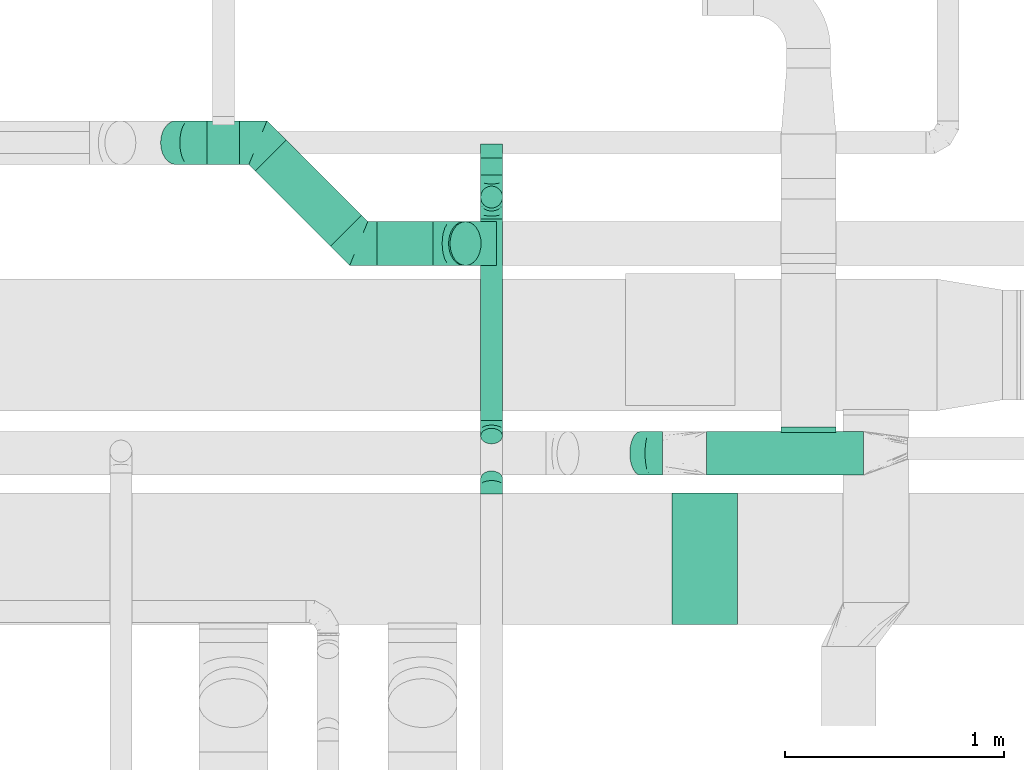
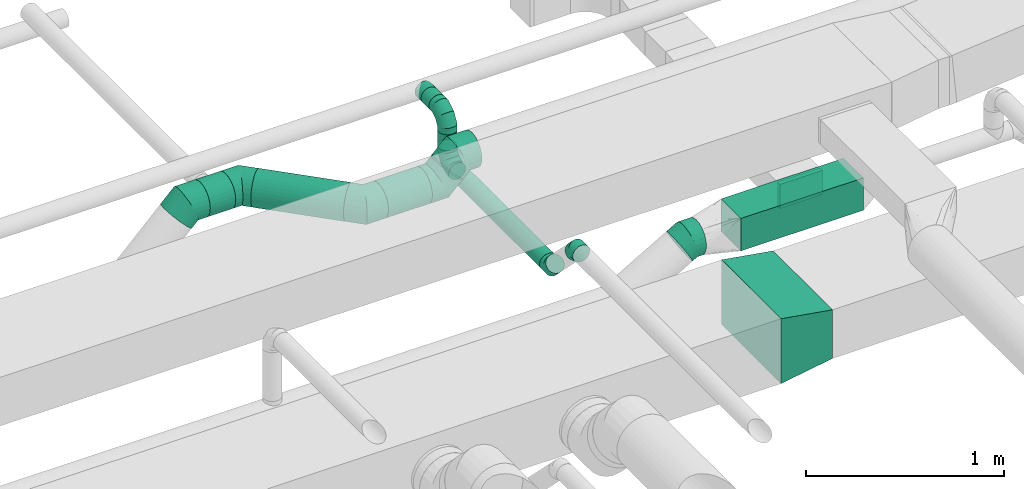
# One storey, part 42 of 60: 13 flow fittings, 8 flow segments.
"""IFC2X3 building model written with IfcOpenShell, lengths in millimetres."""

from ifc_helpers import new_model, entity, si_unit, converted_unit, derived_unit, direction, frame, origin, origin_2d_with_axis, place, context, subcontext, project, spatial, polyline, rectangle, circle, outline, extrude, faceted_brep, source, transform, mapped, material, type_object, type_shapes, element, save


model = new_model("IFC2X3")

# Units and contexts
model_context = context("Model", 3, precision=0.01, world=origin(), true_north=direction((6.12303176911189e-17, 1.0)))
body_context = subcontext(model_context, "Body", "Model", "MODEL_VIEW")
ifc_project = project(units=[si_unit("LENGTHUNIT", "METRE", prefix="MILLI"), si_unit("AREAUNIT", "SQUARE_METRE"), si_unit("VOLUMEUNIT", "CUBIC_METRE"), converted_unit("PLANEANGLEUNIT", "DEGREE", entity("IfcRatioMeasure", 0.0174532925199433), si_unit("PLANEANGLEUNIT", "RADIAN"), dimensions=[0, 0, 0, 0, 0, 0, 0]), si_unit("MASSUNIT", "GRAM", prefix="KILO"), derived_unit("MASSDENSITYUNIT", [(si_unit("MASSUNIT", "GRAM", prefix="KILO"), 1), (si_unit("LENGTHUNIT", "METRE"), -3)]), derived_unit("MOMENTOFINERTIAUNIT", [(si_unit("LENGTHUNIT", "METRE"), 4)]), si_unit("TIMEUNIT", "SECOND"), si_unit("FREQUENCYUNIT", "HERTZ"), si_unit("THERMODYNAMICTEMPERATUREUNIT", "DEGREE_CELSIUS"), derived_unit("THERMALTRANSMITTANCEUNIT", [(si_unit("MASSUNIT", "GRAM", prefix="KILO"), 1), (si_unit("THERMODYNAMICTEMPERATUREUNIT", "KELVIN"), -1), (si_unit("TIMEUNIT", "SECOND"), -3)]), derived_unit("VOLUMETRICFLOWRATEUNIT", [(si_unit("LENGTHUNIT", "METRE"), 3), (si_unit("TIMEUNIT", "SECOND"), -1)]), derived_unit("MASSFLOWRATEUNIT", [(si_unit("MASSUNIT", "GRAM", prefix="KILO"), 1), (si_unit("TIMEUNIT", "SECOND"), -1)]), derived_unit("ROTATIONALFREQUENCYUNIT", [(si_unit("TIMEUNIT", "SECOND"), -1)]), si_unit("ELECTRICCURRENTUNIT", "AMPERE"), si_unit("ELECTRICVOLTAGEUNIT", "VOLT"), si_unit("POWERUNIT", "WATT"), si_unit("FORCEUNIT", "NEWTON", prefix="KILO"), si_unit("ILLUMINANCEUNIT", "LUX"), si_unit("LUMINOUSFLUXUNIT", "LUMEN"), si_unit("LUMINOUSINTENSITYUNIT", "CANDELA"), derived_unit("USERDEFINED", [(si_unit("MASSUNIT", "GRAM", prefix="KILO"), -1), (si_unit("LENGTHUNIT", "METRE"), -2), (si_unit("TIMEUNIT", "SECOND"), 3), (si_unit("LUMINOUSFLUXUNIT", "LUMEN"), 1)]), derived_unit("LINEARVELOCITYUNIT", [(si_unit("LENGTHUNIT", "METRE"), 1), (si_unit("TIMEUNIT", "SECOND"), -1)]), si_unit("PRESSUREUNIT", "PASCAL"), derived_unit("USERDEFINED", [(si_unit("LENGTHUNIT", "METRE"), -2), (si_unit("MASSUNIT", "GRAM", prefix="KILO"), 1), (si_unit("TIMEUNIT", "SECOND"), -2)]), derived_unit("LINEARFORCEUNIT", [(si_unit("MASSUNIT", "GRAM", prefix="KILO"), 1), (si_unit("LENGTHUNIT", "METRE"), 1), (si_unit("TIMEUNIT", "SECOND"), -2), (si_unit("LENGTHUNIT", "METRE"), -1)]), derived_unit("PLANARFORCEUNIT", [(si_unit("MASSUNIT", "GRAM", prefix="KILO"), 1), (si_unit("LENGTHUNIT", "METRE"), 1), (si_unit("TIMEUNIT", "SECOND"), -2), (si_unit("LENGTHUNIT", "METRE"), -2)])], contexts=[model_context])

# Site, building, storey
site_placement = place(None, origin())
site = spatial("IfcSite", under=ifc_project, at=site_placement, CompositionType="ELEMENT")
building_placement = place(site_placement, origin())
building = spatial("IfcBuilding", under=site, at=building_placement, CompositionType="ELEMENT")
storey_placement = place(building_placement, frame((0.0, 0.0, 19800.0)))
storey = spatial("IfcBuildingStorey", under=building, at=storey_placement, CompositionType="ELEMENT", Elevation=19800.0)

# Flow segments
duct_segment_type_1 = type_object("IfcDuctSegmentType", PredefinedType="NOTDEFINED")
flow_segment_1_placement = place(storey_placement, frame((59695.58, 8770.01, 3225.0)))
element("IfcFlowSegment", 1, at=flow_segment_1_placement, inside=storey, type_object=duct_segment_type_1, context=body_context, shape_type="SweptSolid", body=[
    extrude(rectangle(XDim=714.972880388405, YDim=200.0, at=origin_2d_with_axis()), frame((357.49, 100.0, 0.0), z_axis=(0.0, 0.0, 1.0), x_axis=(-1.0, 0.0, 0.0)), (0.0, 0.0, 1.0), 199.999999999998),
])
duct_segment_type_2 = type_object("IfcDuctSegmentType", PredefinedType="NOTDEFINED")
flow_segment_2_placement = place(storey_placement, frame((58664.18, 9019.16, 3300.13)))
element("IfcFlowSegment", 2, at=flow_segment_2_placement, inside=storey, type_object=duct_segment_type_2, context=body_context, shape_type="SweptSolid", body=[
    extrude(circle(Radius=50.0, at=origin_2d_with_axis()), frame((51.6, 0.0, 51.6), z_axis=(0.0, 1.0, 0.0), x_axis=(1.0, 0.0, 0.0)), (0.0, 0.0, 1.0), 918.578643762716),
])
flow_segment_3_placement = place(storey_placement, frame((58664.18, 9986.14, 3451.72)))
element("IfcFlowSegment", 3, at=flow_segment_3_placement, inside=storey, type_object=duct_segment_type_2, context=body_context, shape_type="SweptSolid", body=[
    extrude(circle(Radius=50.0, at=origin_2d_with_axis()), frame((51.6, 51.6, 0.0), z_axis=(0.0, 0.0, 1.0), x_axis=(-1.0, 0.0, 0.0)), (0.0, 0.0, 1.0), 98.2773855639107),
])
flow_segment_4_placement = place(storey_placement, frame((58664.18, 10137.74, 3598.4)))
element("IfcFlowSegment", 4, at=flow_segment_4_placement, inside=storey, type_object=duct_segment_type_2, context=body_context, shape_type="SweptSolid", body=[
    extrude(circle(Radius=50.0, at=origin_2d_with_axis()), frame((51.6, 0.0, 51.6), z_axis=(0.0, 1.0, 0.0), x_axis=(-1.0, 0.0, 0.0)), (0.0, 0.0, 1.0), 77.8806642438999),
])
flow_segment_5_placement = place(storey_placement, frame((58518.17, 9724.4, 3412.43)))
element("IfcFlowSegment", 5, at=flow_segment_5_placement, inside=storey, type_object=duct_segment_type_2, context=body_context, shape_type="SweptSolid", body=[
    extrude(circle(Radius=100.0, at=origin_2d_with_axis()), frame((72.31, 101.6, 72.31), z_axis=(0.707106781186548, 0.0, 0.707106781186548), x_axis=(0.0, 1.0, 0.0)), (0.0, 0.0, 1.0), 9.46176130839337),
])
flow_segment_6_placement = place(storey_placement, frame((58193.08, 9724.4, 3324.56)))
element("IfcFlowSegment", 6, at=flow_segment_6_placement, inside=storey, type_object=duct_segment_type_2, context=body_context, shape_type="SweptSolid", body=[
    extrude(circle(Radius=100.0, at=origin_2d_with_axis()), frame((0.0, 101.6, 101.6), z_axis=(1.0, 0.0, 0.0), x_axis=(0.0, 1.0, 0.0)), (0.0, 0.0, 1.0), 255.972236219953),
])
flow_segment_7_placement = place(storey_placement, frame((57636.89, 9812.27, 3324.56)))
element("IfcFlowSegment", 7, at=flow_segment_7_placement, inside=storey, type_object=duct_segment_type_2, context=body_context, shape_type="SweptSolid", body=[
    extrude(circle(Radius=100.0, at=origin_2d_with_axis()), frame((72.31, 414.77, 101.6), z_axis=(0.707106781186523, -0.707106781186572, 0.0), x_axis=(0.707106781186572, 0.707106781186523, 0.0)), (0.0, 0.0, 1.0), 484.318928738875),
])
flow_segment_8_placement = place(storey_placement, frame((57419.32, 10184.02, 3324.56)))
element("IfcFlowSegment", 8, at=flow_segment_8_placement, inside=storey, type_object=duct_segment_type_2, context=body_context, shape_type="SweptSolid", body=[
    extrude(circle(Radius=100.0, at=origin_2d_with_axis()), frame((0.0, 101.6, 101.6), z_axis=(1.0, 0.0, 0.0), x_axis=(0.0, 1.0, 0.0)), (0.0, 0.0, 1.0), 148.455148137683),
])

# Flow fittings
ifc_material = material()
duct_fitting_type_1 = type_object("IfcDuctFittingType", PredefinedType="NOTDEFINED", material=ifc_material)
shared_shape_1 = source(origin(), body_context, "Body", "SweptSolid", [
    extrude(outline(polyline([(-123.27, -172.61), (180.87, -172.61), (115.05, 221.93), (-172.64, 123.3), (-123.27, -172.61)])), frame((150.0, -300.0, 0.03), z_axis=(0.0, 1.0, 0.0), x_axis=(0.986366827682647, 0.0, 0.164561481663454)), (0.0, 0.0, 1.0), 600.0),
])
type_shapes(duct_fitting_type_1, [shared_shape_1])
flow_fitting_1_placement = place(storey_placement, frame((59837.69, 8389.45, 3074.95), z_axis=(-8.63213559554975e-06, 0.0, 1.0), x_axis=(-1.0, 0.0, -8.63213559554975e-06)))
element("IfcFlowFitting", 9, at=flow_fitting_1_placement, inside=storey, type_object=duct_fitting_type_1, material=ifc_material, context=body_context, shape_type="MappedRepresentation", body=[
    mapped(shared_shape_1, transform((0.0, 0.0, 0.0), scale=1.0)),
])
duct_fitting_type_2 = type_object("IfcDuctFittingType", PredefinedType="NOTDEFINED", material=ifc_material)
shared_shape_2 = source(origin(), body_context, "Body", "SweptSolid", [
    extrude(rectangle(XDim=250.0, YDim=26.096, at=origin_2d_with_axis()), frame((6.95, 0.0, -75.0), z_axis=(0.0, 0.0, 1.0), x_axis=(0.0, -1.0, 0.0)), (0.0, 0.0, 1.0), 150.0),
])
type_shapes(duct_fitting_type_2, [shared_shape_2])
flow_fitting_2_placement = place(storey_placement, frame((60160.56, 8970.01, 3322.6), z_axis=(0.0, 0.0, -1.0), x_axis=(0.0, 1.0, 0.0)))
element("IfcFlowFitting", 10, at=flow_fitting_2_placement, inside=storey, type_object=duct_fitting_type_2, material=ifc_material, context=body_context, shape_type="MappedRepresentation", body=[
    mapped(shared_shape_2, transform((0.0, 0.0, 0.0), scale=1.0)),
])
duct_fitting_type_3 = type_object("IfcDuctFittingType", PredefinedType="NOTDEFINED", material=ifc_material)
shared_shape_3 = source(origin(), body_context, "Body", "Brep", [
    faceted_brep([(-100.0, 0.0, -50.0), (-100.0, -12.94, -48.3), (-100.0, -25.0, -43.3), (-100.0, -35.36, -35.36), (-100.0, -43.3, -25.0), (-100.0, -48.3, -12.94), (-100.0, -50.0, 0.0), (-100.0, -48.3, 12.94), (-100.0, -43.3, 25.0), (-100.0, -35.36, 35.36), (-100.0, -25.0, 43.3), (-100.0, -12.94, 48.3), (-100.0, 0.0, 50.0), (-100.0, 12.94, 48.3), (-100.0, 25.0, 43.3), (-100.0, 35.36, 35.36), (-100.0, 43.3, 25.0), (-100.0, 48.3, 12.94), (-100.0, 50.0, 0.0), (-100.0, 48.3, -12.94), (-100.0, 43.3, -25.0), (-100.0, 35.36, -35.36), (-100.0, 25.0, -43.3), (-100.0, 12.94, -48.3), (-76.67, 12.94, 48.3), (-79.9, 25.0, 43.3), (-73.21, 0.0, 50.0), (-82.68, 35.36, 35.36), (-86.15, 48.3, 12.94), (-86.6, 50.0, 0.0), (-84.81, 43.3, 25.0), (-84.81, 43.3, -25.0), (-82.68, 35.36, -35.36), (-86.15, 48.3, -12.94), (-76.67, 12.94, -48.3), (-73.21, 0.0, -50.0), (-79.9, 25.0, -43.3), (-69.74, -12.94, -48.3), (-66.51, -25.0, -43.3), (-63.73, -35.36, -35.36), (-61.6, -43.3, -25.0), (-60.26, -48.3, -12.94), (-59.81, -50.0, 0.0), (-60.26, -48.3, 12.94), (-61.6, -43.3, 25.0), (-63.73, -35.36, 35.36), (-66.51, -25.0, 43.3), (-69.74, -12.94, 48.3), (-36.27, 36.27, 48.3), (-45.1, 45.1, 43.3), (-26.79, 26.79, 50.0), (-52.68, 52.68, 35.36), (-58.49, 58.49, 25.0), (-62.15, 62.15, 12.94), (-63.4, 63.4, 0.0), (-62.15, 62.15, -12.94), (-58.49, 58.49, -25.0), (-52.68, 52.68, -35.36), (-36.27, 36.27, -48.3), (-26.79, 26.79, -50.0), (-45.1, 45.1, -43.3), (-17.32, 17.32, -48.3), (-8.49, 8.49, -43.3), (-0.91, 0.91, -35.36), (4.9, -4.9, -25.0), (8.56, -8.56, -12.94), (9.81, -9.81, 0.0), (8.56, -8.56, 12.94), (4.9, -4.9, 25.0), (-0.91, 0.91, 35.36), (-8.49, 8.49, 43.3), (-17.32, 17.32, 48.3), (-12.94, 76.67, 48.3), (-25.0, 79.9, 43.3), (0.0, 73.21, 50.0), (-35.36, 82.68, 35.36), (-43.3, 84.81, 25.0), (-48.3, 86.15, 12.94), (-50.0, 86.6, 0.0), (-48.3, 86.15, -12.94), (-43.3, 84.81, -25.0), (-35.36, 82.68, -35.36), (-12.94, 76.67, -48.3), (0.0, 73.21, -50.0), (-25.0, 79.9, -43.3), (12.94, 69.74, -48.3), (25.0, 66.51, -43.3), (35.36, 63.73, -35.36), (43.3, 61.6, -25.0), (48.3, 60.26, -12.94), (50.0, 59.81, 0.0), (48.3, 60.26, 12.94), (43.3, 61.6, 25.0), (35.36, 63.73, 35.36), (25.0, 66.51, 43.3), (12.94, 69.74, 48.3), (-12.94, 100.0, -48.3), (-25.0, 100.0, -43.3), (-35.36, 100.0, -35.36), (-43.3, 100.0, -25.0), (-48.3, 100.0, -12.94), (-50.0, 100.0, 0.0), (-48.3, 100.0, 12.94), (-43.3, 100.0, 25.0), (-35.36, 100.0, 35.36), (-25.0, 100.0, 43.3), (-12.94, 100.0, 48.3), (0.0, 100.0, 50.0), (12.94, 100.0, 48.3), (25.0, 100.0, 43.3), (35.36, 100.0, 35.36), (43.3, 100.0, 25.0), (48.3, 100.0, 12.94), (50.0, 100.0, 0.0), (48.3, 100.0, -12.94), (43.3, 100.0, -25.0), (35.36, 100.0, -35.36), (25.0, 100.0, -43.3), (12.94, 100.0, -48.3), (0.0, 100.0, -50.0)], [[[0, 1, 2, 3, 4, 5, 6, 7, 8, 9, 10, 11, 12, 13, 14, 15, 16, 17, 18, 19, 20, 21, 22, 23]], [[24, 25, 14, 13]], [[26, 24, 13, 12]], [[14, 25, 27, 15]], [[28, 29, 18, 17]], [[30, 28, 17, 16]], [[15, 27, 30, 16]], [[20, 31, 32, 21]], [[33, 31, 20, 19]], [[18, 29, 33, 19]], [[34, 35, 0, 23]], [[36, 34, 23, 22]], [[32, 36, 22, 21]], [[2, 1, 37, 38]], [[3, 2, 38, 39]], [[0, 35, 37, 1]], [[5, 4, 40, 41]], [[6, 5, 41, 42]], [[3, 39, 40, 4]], [[6, 42, 43, 7]], [[7, 43, 44, 8]], [[8, 44, 45, 9]], [[10, 46, 47, 11]], [[11, 47, 26, 12]], [[10, 9, 45, 46]], [[48, 49, 25, 24]], [[50, 48, 24, 26]], [[27, 25, 49, 51]], [[52, 53, 28, 30]], [[51, 52, 30, 27]], [[29, 28, 53, 54]], [[55, 56, 31, 33]], [[54, 55, 33, 29]], [[57, 32, 31, 56]], [[58, 59, 35, 34]], [[60, 58, 34, 36]], [[57, 60, 36, 32]], [[37, 35, 59, 61]], [[38, 37, 61, 62]], [[39, 38, 62, 63]], [[41, 40, 64, 65]], [[42, 41, 65, 66]], [[63, 64, 40, 39]], [[43, 42, 66, 67]], [[44, 43, 67, 68]], [[68, 69, 45, 44]], [[46, 45, 69, 70]], [[47, 46, 70, 71]], [[26, 47, 71, 50]], [[72, 73, 49, 48]], [[74, 72, 48, 50]], [[51, 49, 73, 75]], [[76, 77, 53, 52]], [[75, 76, 52, 51]], [[54, 53, 77, 78]], [[79, 80, 56, 55]], [[78, 79, 55, 54]], [[81, 57, 56, 80]], [[82, 83, 59, 58]], [[84, 82, 58, 60]], [[81, 84, 60, 57]], [[61, 59, 83, 85]], [[62, 61, 85, 86]], [[63, 62, 86, 87]], [[65, 64, 88, 89]], [[66, 65, 89, 90]], [[87, 88, 64, 63]], [[67, 66, 90, 91]], [[68, 67, 91, 92]], [[92, 93, 69, 68]], [[70, 69, 93, 94]], [[71, 70, 94, 95]], [[50, 71, 95, 74]], [[96, 97, 98, 99, 100, 101, 102, 103, 104, 105, 106, 107, 108, 109, 110, 111, 112, 113, 114, 115, 116, 117, 118, 119]], [[72, 74, 107, 106]], [[73, 72, 106, 105]], [[75, 73, 105, 104]], [[77, 76, 103, 102]], [[78, 77, 102, 101]], [[75, 104, 103, 76]], [[78, 101, 100, 79]], [[79, 100, 99, 80]], [[80, 99, 98, 81]], [[96, 119, 83, 82]], [[97, 96, 82, 84]], [[84, 81, 98, 97]], [[83, 119, 118, 85]], [[85, 118, 117, 86]], [[86, 117, 116, 87]], [[88, 115, 114, 89]], [[89, 114, 113, 90]], [[87, 116, 115, 88]], [[91, 90, 113, 112]], [[92, 91, 112, 111]], [[93, 92, 111, 110]], [[95, 94, 109, 108]], [[74, 95, 108, 107]], [[110, 109, 94, 93]]]),
])
type_shapes(duct_fitting_type_3, [shared_shape_3])
for number, where, z_axis, x_axis in (
    (11, (58715.78, 10037.74, 3351.72), (1.0, 0.0, 0.0), (0.0, 1.0, 0.0)),
    (12, (58715.78, 10037.74, 3650.0), (-1.0, 0.0, 0.0), (0.0, 0.0, 1.0)),
):
    element("IfcFlowFitting", number, at=place(storey_placement, frame(where, z_axis=z_axis, x_axis=x_axis)), inside=storey, type_object=duct_fitting_type_3, material=ifc_material, context=body_context, shape_type="MappedRepresentation", body=[
        mapped(shared_shape_3, transform((0.0, 0.0, 0.0), scale=1.0)),
    ])
duct_fitting_type_4 = type_object("IfcDuctFittingType", PredefinedType="NOTDEFINED", material=ifc_material)
shared_shape_4 = source(origin(), body_context, "Body", "Brep", [
    faceted_brep([(-41.42, 0.0, -50.0), (-41.42, -12.94, -48.3), (-41.42, -25.0, -43.3), (-41.42, -35.36, -35.36), (-41.42, -43.3, -25.0), (-41.42, -48.3, -12.94), (-41.42, -50.0, 0.0), (-41.42, -48.3, 12.94), (-41.42, -43.3, 25.0), (-41.42, -35.36, 35.36), (-41.42, -25.0, 43.3), (-41.42, -12.94, 48.3), (-41.42, 0.0, 50.0), (-41.42, 12.94, 48.3), (-41.42, 25.0, 43.3), (-41.42, 35.36, 35.36), (-41.42, 43.3, 25.0), (-41.42, 48.3, 12.94), (-41.42, 50.0, 0.0), (-41.42, 48.3, -12.94), (-41.42, 43.3, -25.0), (-41.42, 35.36, -35.36), (-41.42, 25.0, -43.3), (-41.42, 12.94, -48.3), (-5.36, 12.94, 48.3), (-10.36, 25.0, 43.3), (0.0, 0.0, 50.0), (-14.64, 35.36, 35.36), (-20.0, 48.3, 12.94), (-20.71, 50.0, 0.0), (-17.94, 43.3, 25.0), (-17.94, 43.3, -25.0), (-14.64, 35.36, -35.36), (-20.0, 48.3, -12.94), (-5.36, 12.94, -48.3), (0.0, 0.0, -50.0), (-10.36, 25.0, -43.3), (5.36, -12.94, -48.3), (10.36, -25.0, -43.3), (14.64, -35.36, -35.36), (17.94, -43.3, -25.0), (20.0, -48.3, -12.94), (20.71, -50.0, 0.0), (20.0, -48.3, 12.94), (17.94, -43.3, 25.0), (14.64, -35.36, 35.36), (10.36, -25.0, 43.3), (5.36, -12.94, 48.3), (29.29, 29.29, 50.0), (20.14, 38.44, 48.3), (11.61, 46.97, 43.3), (4.29, 54.29, 35.36), (-1.33, 59.91, 25.0), (-4.86, 63.44, 12.94), (-6.07, 64.64, 0.0), (-4.86, 63.44, -12.94), (-1.33, 59.91, -25.0), (4.29, 54.29, -35.36), (11.61, 46.97, -43.3), (20.14, 38.44, -48.3), (29.29, 29.29, -50.0), (38.44, 20.14, -48.3), (46.97, 11.61, -43.3), (54.29, 4.29, -35.36), (59.91, -1.33, -25.0), (63.44, -4.86, -12.94), (64.64, -6.07, 0.0), (63.44, -4.86, 12.94), (59.91, -1.33, 25.0), (54.29, 4.29, 35.36), (46.97, 11.61, 43.3), (38.44, 20.14, 48.3)], [[[0, 1, 2, 3, 4, 5, 6, 7, 8, 9, 10, 11, 12, 13, 14, 15, 16, 17, 18, 19, 20, 21, 22, 23]], [[24, 25, 14, 13]], [[26, 24, 13, 12]], [[14, 25, 27, 15]], [[28, 29, 18, 17]], [[30, 28, 17, 16]], [[16, 15, 27, 30]], [[20, 31, 32, 21]], [[33, 31, 20, 19]], [[18, 29, 33, 19]], [[34, 35, 0, 23]], [[36, 34, 23, 22]], [[32, 36, 22, 21]], [[1, 0, 35, 37]], [[2, 1, 37, 38]], [[38, 39, 3, 2]], [[5, 4, 40, 41]], [[6, 5, 41, 42]], [[39, 40, 4, 3]], [[6, 42, 43, 7]], [[7, 43, 44, 8]], [[8, 44, 45, 9]], [[9, 45, 46, 10]], [[10, 46, 47, 11]], [[26, 12, 11, 47]], [[24, 26, 48, 49]], [[25, 24, 49, 50]], [[27, 25, 50, 51]], [[28, 30, 52, 53]], [[29, 28, 53, 54]], [[27, 51, 52, 30]], [[29, 54, 55, 33]], [[33, 55, 56, 31]], [[31, 56, 57, 32]], [[36, 58, 59, 34]], [[34, 59, 60, 35]], [[36, 32, 57, 58]], [[61, 62, 38, 37]], [[60, 61, 37, 35]], [[63, 39, 38, 62]], [[40, 64, 65, 41]], [[41, 65, 66, 42]], [[64, 40, 39, 63]], [[43, 42, 66, 67]], [[44, 43, 67, 68]], [[68, 69, 45, 44]], [[47, 46, 70, 71]], [[26, 47, 71, 48]], [[69, 70, 46, 45]], [[59, 58, 57, 56, 55, 54, 53, 52, 51, 50, 49, 48, 71, 70, 69, 68, 67, 66, 65, 64, 63, 62, 61, 60]]]),
])
type_shapes(duct_fitting_type_4, [shared_shape_4])
for number, where, z_axis, x_axis in (
    (13, (58715.78, 8724.9, 3604.57), (-1.0, 0.0, 0.0), (0.0, 1.0, 0.0)),
    (14, (58715.78, 8977.74, 3351.72), (1.0, 0.0, 0.0), (0.0, 0.707106781186525, -0.70710678118657)),
):
    element("IfcFlowFitting", number, at=place(storey_placement, frame(where, z_axis=z_axis, x_axis=x_axis)), inside=storey, type_object=duct_fitting_type_4, material=ifc_material, context=body_context, shape_type="MappedRepresentation", body=[
        mapped(shared_shape_4, transform((0.0, 0.0, 0.0), scale=1.0)),
    ])
duct_fitting_type_5 = type_object("IfcDuctFittingType", PredefinedType="NOTDEFINED", material=ifc_material)
shared_shape_5 = source(origin(), body_context, "Body", "Brep", [
    faceted_brep([(20.0, 12.94, -48.3), (20.0, 25.0, -43.3), (20.0, 35.36, -35.36), (20.0, 43.3, -25.0), (20.0, 48.3, -12.94), (20.0, 50.0, 0.0), (20.0, 48.3, 12.94), (20.0, 43.3, 25.0), (20.0, 35.36, 35.36), (20.0, 25.0, 43.3), (20.0, 12.94, 48.3), (20.0, 0.0, 50.0), (20.0, -12.94, 48.3), (20.0, -25.0, 43.3), (20.0, -35.36, 35.36), (20.0, -43.3, 25.0), (20.0, -48.3, 12.94), (20.0, -50.0, 0.0), (20.0, -48.3, -12.94), (20.0, -43.3, -25.0), (20.0, -35.36, -35.36), (20.0, -25.0, -43.3), (20.0, -12.94, -48.3), (20.0, 0.0, -50.0), (0.0, 0.0, 50.0), (0.0, 12.94, 48.3), (-43.9, 12.94, 48.3), (-43.9, 0.0, 50.0), (0.0, 25.0, 43.3), (-43.9, 25.0, 43.3), (0.0, 35.36, 35.36), (-43.9, 35.36, 35.36), (0.0, 43.3, 25.0), (0.0, 48.3, 12.94), (-43.9, 48.3, 12.94), (-43.9, 43.3, 25.0), (0.0, 50.0, 0.0), (-43.9, 50.0, 0.0), (0.0, 48.3, -12.94), (-43.9, 48.3, -12.94), (0.0, 43.3, -25.0), (-43.9, 43.3, -25.0), (0.0, 35.36, -35.36), (-43.9, 35.36, -35.36), (0.0, 25.0, -43.3), (0.0, 12.94, -48.3), (-43.9, 12.94, -48.3), (-43.9, 25.0, -43.3), (0.0, 0.0, -50.0), (-43.9, 0.0, -50.0), (0.0, -12.94, -48.3), (-43.9, -12.94, -48.3), (0.0, -25.0, -43.3), (-43.9, -25.0, -43.3), (0.0, -35.36, -35.36), (-43.9, -35.36, -35.36), (0.0, -43.3, -25.0), (0.0, -48.3, -12.94), (-43.9, -48.3, -12.94), (-43.9, -43.3, -25.0), (0.0, -50.0, 0.0), (-43.9, -50.0, 0.0), (0.0, -48.3, 12.94), (-43.9, -48.3, 12.94), (0.0, -43.3, 25.0), (-43.9, -43.3, 25.0), (0.0, -35.36, 35.36), (-43.9, -35.36, 35.36), (0.0, -25.0, 43.3), (0.0, -12.94, 48.3), (-43.9, -12.94, 48.3), (-43.9, -25.0, 43.3)], [[[0, 1, 2, 3, 4, 5, 6, 7, 8, 9, 10, 11, 12, 13, 14, 15, 16, 17, 18, 19, 20, 21, 22, 23]], [[24, 11, 10, 25, 26, 27]], [[25, 10, 9, 28, 29, 26]], [[28, 9, 8, 30, 31, 29]], [[32, 7, 6, 33, 34, 35]], [[33, 6, 5, 36, 37, 34]], [[30, 8, 7, 32, 35, 31]], [[36, 5, 4, 38, 39, 37]], [[38, 4, 3, 40, 41, 39]], [[40, 3, 2, 42, 43, 41]], [[44, 1, 0, 45, 46, 47]], [[45, 0, 23, 48, 49, 46]], [[42, 2, 1, 44, 47, 43]], [[48, 23, 22, 50, 51, 49]], [[50, 22, 21, 52, 53, 51]], [[52, 21, 20, 54, 55, 53]], [[56, 19, 18, 57, 58, 59]], [[57, 18, 17, 60, 61, 58]], [[54, 20, 19, 56, 59, 55]], [[60, 17, 16, 62, 63, 61]], [[62, 16, 15, 64, 65, 63]], [[64, 15, 14, 66, 67, 65]], [[68, 13, 12, 69, 70, 71]], [[69, 12, 11, 24, 27, 70]], [[66, 14, 13, 68, 71, 67]], [[49, 51, 53, 55, 59, 58, 61, 63, 65, 67, 71, 70, 27, 26, 29, 31, 35, 34, 37, 39, 41, 43, 47, 46]]]),
])
type_shapes(duct_fitting_type_5, [shared_shape_5])
flow_fitting_3_placement = place(storey_placement, frame((58715.78, 10235.62, 3650.0), z_axis=(0.0, 0.0, -1.0), x_axis=(0.0, -1.0, 0.0)))
element("IfcFlowFitting", 15, at=flow_fitting_3_placement, inside=storey, type_object=duct_fitting_type_5, material=ifc_material, context=body_context, shape_type="MappedRepresentation", body=[
    mapped(shared_shape_5, transform((0.0, 0.0, 0.0), scale=1.0)),
])
duct_fitting_type_6 = type_object("IfcDuctFittingType", PredefinedType="NOTDEFINED", material=ifc_material)
shared_shape_6 = source(origin(), body_context, "Body", "Brep", [
    faceted_brep([(-82.84, 0.0, -100.0), (-82.84, -25.88, -96.59), (-82.84, -50.0, -86.6), (-82.84, -70.71, -70.71), (-82.84, -86.6, -50.0), (-82.84, -96.59, -25.88), (-82.84, -100.0, 0.0), (-82.84, -96.59, 25.88), (-82.84, -86.6, 50.0), (-82.84, -70.71, 70.71), (-82.84, -50.0, 86.6), (-82.84, -25.88, 96.59), (-82.84, 0.0, 100.0), (-82.84, 25.88, 96.59), (-82.84, 50.0, 86.6), (-82.84, 70.71, 70.71), (-82.84, 86.6, 50.0), (-82.84, 96.59, 25.88), (-82.84, 100.0, 0.0), (-82.84, 96.59, -25.88), (-82.84, 86.6, -50.0), (-82.84, 70.71, -70.71), (-82.84, 50.0, -86.6), (-82.84, 25.88, -96.59), (-10.72, 25.88, 96.59), (-20.71, 50.0, 86.6), (0.0, 0.0, 100.0), (-29.29, 70.71, 70.71), (-35.87, 86.6, 50.0), (-40.01, 96.59, 25.88), (-41.42, 100.0, 0.0), (-40.01, 96.59, -25.88), (-35.87, 86.6, -50.0), (-29.29, 70.71, -70.71), (-10.72, 25.88, -96.59), (0.0, 0.0, -100.0), (-20.71, 50.0, -86.6), (10.72, -25.88, -96.59), (20.71, -50.0, -86.6), (29.29, -70.71, -70.71), (35.87, -86.6, -50.0), (40.01, -96.59, -25.88), (41.42, -100.0, 0.0), (40.01, -96.59, 25.88), (35.87, -86.6, 50.0), (29.29, -70.71, 70.71), (20.71, -50.0, 86.6), (10.72, -25.88, 96.59), (58.58, 58.58, 100.0), (40.28, 76.88, 96.59), (23.22, 93.93, 86.6), (8.58, 108.58, 70.71), (-2.66, 119.82, 50.0), (-9.72, 126.88, 25.88), (-12.13, 129.29, 0.0), (-9.72, 126.88, -25.88), (-2.66, 119.82, -50.0), (8.58, 108.58, -70.71), (23.22, 93.93, -86.6), (40.28, 76.88, -96.59), (58.58, 58.58, -100.0), (76.88, 40.28, -96.59), (93.93, 23.22, -86.6), (108.58, 8.58, -70.71), (119.82, -2.66, -50.0), (126.88, -9.72, -25.88), (129.29, -12.13, 0.0), (126.88, -9.72, 25.88), (119.82, -2.66, 50.0), (108.58, 8.58, 70.71), (93.93, 23.22, 86.6), (76.88, 40.28, 96.59)], [[[0, 1, 2, 3, 4, 5, 6, 7, 8, 9, 10, 11, 12, 13, 14, 15, 16, 17, 18, 19, 20, 21, 22, 23]], [[24, 25, 14, 13]], [[26, 24, 13, 12]], [[14, 25, 27, 15]], [[28, 29, 17, 16]], [[28, 16, 15, 27]], [[30, 18, 17, 29]], [[31, 32, 20, 19]], [[30, 31, 19, 18]], [[32, 33, 21, 20]], [[34, 35, 0, 23]], [[36, 34, 23, 22]], [[33, 36, 22, 21]], [[1, 0, 35, 37]], [[2, 1, 37, 38]], [[38, 39, 3, 2]], [[5, 4, 40, 41]], [[6, 5, 41, 42]], [[39, 40, 4, 3]], [[6, 42, 43, 7]], [[7, 43, 44, 8]], [[8, 44, 45, 9]], [[9, 45, 46, 10]], [[10, 46, 47, 11]], [[26, 12, 11, 47]], [[24, 26, 48, 49]], [[25, 24, 49, 50]], [[27, 25, 50, 51]], [[29, 28, 52, 53]], [[30, 29, 53, 54]], [[51, 52, 28, 27]], [[30, 54, 55, 31]], [[31, 55, 56, 32]], [[57, 33, 32, 56]], [[36, 58, 59, 34]], [[34, 59, 60, 35]], [[58, 36, 33, 57]], [[35, 60, 61, 37]], [[37, 61, 62, 38]], [[63, 39, 38, 62]], [[40, 64, 65, 41]], [[41, 65, 66, 42]], [[64, 40, 39, 63]], [[43, 42, 66, 67]], [[44, 43, 67, 68]], [[68, 69, 45, 44]], [[47, 46, 70, 71]], [[26, 47, 71, 48]], [[69, 70, 46, 45]], [[59, 58, 57, 56, 55, 54, 53, 52, 51, 50, 49, 48, 71, 70, 69, 68, 67, 66, 65, 64, 63, 62, 61, 60]]]),
])
type_shapes(duct_fitting_type_6, [shared_shape_6])
for number, where, z_axis, x_axis in (
    (16, (58655.74, 9826.0, 3550.0), (0.0, -1.0, 0.0), (-1.0, 0.0, 0.0)),
    (17, (58531.9, 9826.0, 3426.16), (0.0, 1.0, 0.0), (-0.707106781186523, 0.0, -0.707106781186572)),
    (18, (58110.24, 9826.0, 3426.16), (0.0, 0.0, 1.0), (0.707106781186546, -0.707106781186549, 0.0)),
    (19, (57650.62, 10285.62, 3426.16), (0.0, 0.0, 1.0), (-0.707106781186534, 0.707106781186561, 0.0)),
    (20, (57336.47, 10285.62, 3426.16), (0.0, -1.0, 0.0), (-1.0, 0.0, 0.0)),
):
    element("IfcFlowFitting", number, at=place(storey_placement, frame(where, z_axis=z_axis, x_axis=x_axis)), inside=storey, type_object=duct_fitting_type_6, material=ifc_material, context=body_context, shape_type="MappedRepresentation", body=[
        mapped(shared_shape_6, transform((0.0, 0.0, 0.0), scale=1.0)),
    ])
duct_fitting_type_7 = type_object("IfcDuctFittingType", PredefinedType="NOTDEFINED", material=ifc_material)
shared_shape_7 = source(origin(), body_context, "Body", "Brep", [
    faceted_brep([(-53.59, 0.0, -100.0), (-53.59, -25.88, -96.59), (-53.59, -50.0, -86.6), (-53.59, -70.71, -70.71), (-53.59, -86.6, -50.0), (-53.59, -96.59, -25.88), (-53.59, -100.0, 0.0), (-53.59, -96.59, 25.88), (-53.59, -86.6, 50.0), (-53.59, -70.71, 70.71), (-53.59, -50.0, 86.6), (-53.59, -25.88, 96.59), (-53.59, 0.0, 100.0), (-53.59, 25.88, 96.59), (-53.59, 50.0, 86.6), (-53.59, 70.71, 70.71), (-53.59, 86.6, 50.0), (-53.59, 96.59, 25.88), (-53.59, 100.0, 0.0), (-53.59, 96.59, -25.88), (-53.59, 86.6, -50.0), (-53.59, 70.71, -70.71), (-53.59, 50.0, -86.6), (-53.59, 25.88, -96.59), (-6.94, 25.88, 96.59), (-13.4, 50.0, 86.6), (0.0, 0.0, 100.0), (-18.95, 70.71, 70.71), (-25.88, 96.59, 25.88), (-26.79, 100.0, 0.0), (-23.21, 86.6, 50.0), (-23.21, 86.6, -50.0), (-18.95, 70.71, -70.71), (-25.88, 96.59, -25.88), (-6.94, 25.88, -96.59), (0.0, 0.0, -100.0), (-13.4, 50.0, -86.6), (6.94, -25.88, -96.59), (13.4, -50.0, -86.6), (18.95, -70.71, -70.71), (23.21, -86.6, -50.0), (25.88, -96.59, -25.88), (26.79, -100.0, 0.0), (25.88, -96.59, 25.88), (23.21, -86.6, 50.0), (18.95, -70.71, 70.71), (13.4, -50.0, 86.6), (6.94, -25.88, 96.59), (46.41, 26.79, 100.0), (33.47, 49.21, 96.59), (21.41, 70.1, 86.6), (11.05, 88.03, 70.71), (-1.89, 110.45, 25.88), (-3.59, 113.4, 0.0), (3.11, 101.79, 50.0), (-1.89, 110.45, -25.88), (3.11, 101.79, -50.0), (11.05, 88.03, -70.71), (21.41, 70.1, -86.6), (33.47, 49.21, -96.59), (46.41, 26.79, -100.0), (59.35, 4.38, -96.59), (71.41, -16.51, -86.6), (81.77, -34.44, -70.71), (89.71, -48.21, -50.0), (94.71, -56.86, -25.88), (96.41, -59.81, 0.0), (94.71, -56.86, 25.88), (89.71, -48.21, 50.0), (81.77, -34.44, 70.71), (71.41, -16.51, 86.6), (59.35, 4.38, 96.59)], [[[0, 1, 2, 3, 4, 5, 6, 7, 8, 9, 10, 11, 12, 13, 14, 15, 16, 17, 18, 19, 20, 21, 22, 23]], [[24, 25, 14, 13]], [[26, 24, 13, 12]], [[14, 25, 27, 15]], [[28, 29, 18, 17]], [[30, 28, 17, 16]], [[15, 27, 30, 16]], [[20, 31, 32, 21]], [[33, 31, 20, 19]], [[18, 29, 33, 19]], [[34, 35, 0, 23]], [[36, 34, 23, 22]], [[32, 36, 22, 21]], [[1, 0, 35, 37]], [[2, 1, 37, 38]], [[38, 39, 3, 2]], [[5, 4, 40, 41]], [[6, 5, 41, 42]], [[39, 40, 4, 3]], [[6, 42, 43, 7]], [[7, 43, 44, 8]], [[8, 44, 45, 9]], [[9, 45, 46, 10]], [[10, 46, 47, 11]], [[26, 12, 11, 47]], [[24, 26, 48, 49]], [[25, 24, 49, 50]], [[27, 25, 50, 51]], [[52, 53, 29, 28]], [[54, 52, 28, 30]], [[27, 51, 54, 30]], [[29, 53, 55, 33]], [[33, 55, 56, 31]], [[31, 56, 57, 32]], [[36, 58, 59, 34]], [[34, 59, 60, 35]], [[36, 32, 57, 58]], [[61, 62, 38, 37]], [[60, 61, 37, 35]], [[63, 39, 38, 62]], [[40, 64, 65, 41]], [[41, 65, 66, 42]], [[64, 40, 39, 63]], [[43, 42, 66, 67]], [[44, 43, 67, 68]], [[68, 69, 45, 44]], [[47, 46, 70, 71]], [[26, 47, 71, 48]], [[69, 70, 46, 45]], [[59, 58, 57, 56, 55, 53, 52, 54, 51, 50, 49, 48, 71, 70, 69, 68, 67, 66, 65, 64, 63, 62, 61, 60]]]),
])
type_shapes(duct_fitting_type_7, [shared_shape_7])
flow_fitting_4_placement = place(storey_placement, frame((59441.99, 8870.01, 3325.0), z_axis=(0.0, -1.0, 0.0), x_axis=(-1.0, 0.0, 0.0)))
element("IfcFlowFitting", 21, at=flow_fitting_4_placement, inside=storey, type_object=duct_fitting_type_7, material=ifc_material, context=body_context, shape_type="MappedRepresentation", body=[
    mapped(shared_shape_7, transform((0.0, 0.0, 0.0), scale=1.0)),
])

save(model, "model.ifc")
